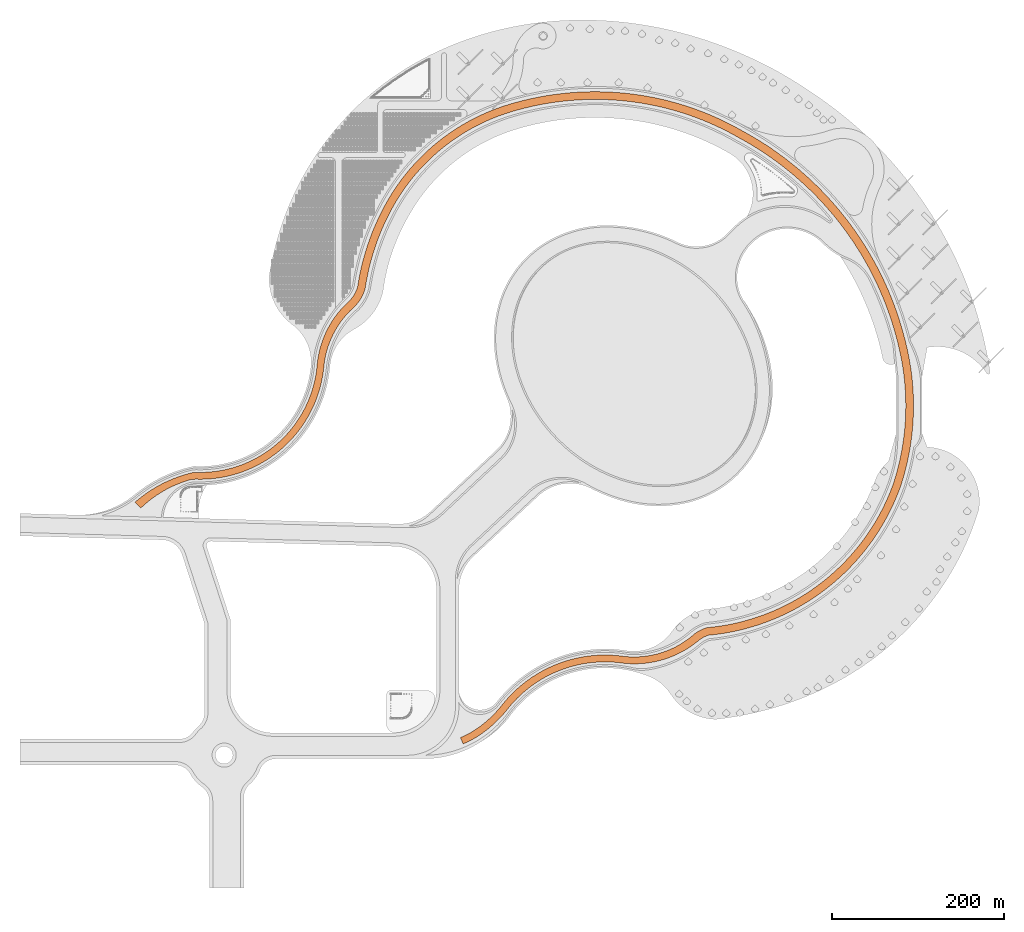
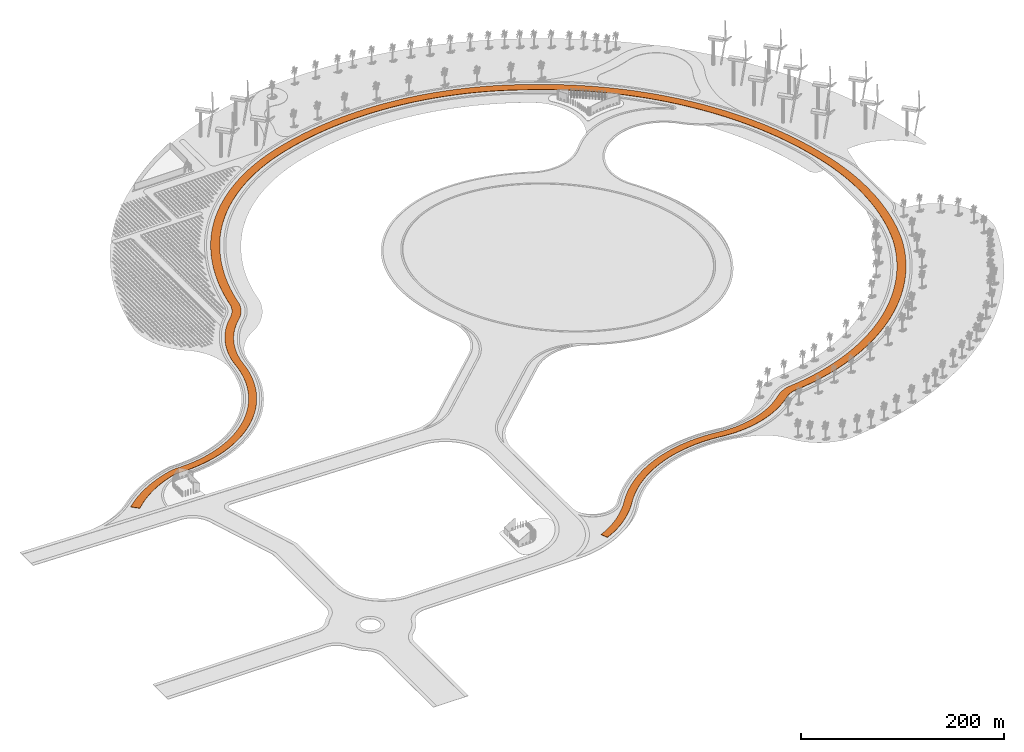
# One storey, part 19 of 39: 1 proxy.
"""IFC2X3 building model written with IfcOpenShell, lengths in millimetres."""

from ifc_helpers import new_model, entity, si_unit, converted_unit, derived_unit, direction, frame, frame_2d, origin, place, context, subcontext, project, spatial, polyline, circle_curve, parameter, trimmed, segment, composite_curve, outline, extrude, source, transform, mapped, material, element, save


model = new_model("IFC2X3")

# Units and contexts
model_context = context("Model", 3, precision=1e-06, world=origin(), true_north=direction((2.0, 6.12303176911189e-17, 1.0)))
context_of_model = context(None, 3, precision=1e-06, world=origin(), true_north=direction((2.0, 6.12303176911189e-17, 1.0)))
body_context = subcontext(model_context, "Body", "Model", "MODEL_VIEW")
ifc_project = project(units=[si_unit("LENGTHUNIT", "METRE", prefix="MILLI"), si_unit("AREAUNIT", "SQUARE_METRE", prefix="MILLI"), si_unit("VOLUMEUNIT", "CUBIC_METRE", prefix="MILLI"), converted_unit("PLANEANGLEUNIT", "DEGREE", entity("IfcRatioMeasure", 0.0174532925199433), si_unit("PLANEANGLEUNIT", "RADIAN"), dimensions=[0, 0, 0, 0, 0, 0, 0]), si_unit("MASSUNIT", "GRAM", prefix="KILO"), si_unit("TIMEUNIT", "SECOND"), si_unit("THERMODYNAMICTEMPERATUREUNIT", "KELVIN"), derived_unit("THERMALTRANSMITTANCEUNIT", [(si_unit("MASSUNIT", "GRAM", prefix="KILO"), 1), (si_unit("THERMODYNAMICTEMPERATUREUNIT", "KELVIN"), -1), (si_unit("TIMEUNIT", "SECOND"), -3)]), derived_unit("VOLUMETRICFLOWRATEUNIT", [(si_unit("LENGTHUNIT", "METRE"), 3), (si_unit("TIMEUNIT", "SECOND"), -1)])], contexts=[model_context, context_of_model])

# Site, building, storey
site_placement = place(None, origin())
site = spatial("IfcSite", under=ifc_project, at=site_placement, CompositionType="ELEMENT")
building_placement = place(site_placement, origin())
building = spatial("IfcBuilding", under=site, at=building_placement, CompositionType="ELEMENT")
storey_placement = place(building_placement, frame((0.0, 0.0, 4000.0)))
storey = spatial("IfcBuildingStorey", under=building, at=storey_placement, Name="Level 2", CompositionType="ELEMENT", Elevation=4000.0)

# Proxy
ifc_material = material(Name="Concrete - Cast In Situ")
shared_shape = source(origin(), body_context, "Body", "SweptSolid", [
    extrude(outline(composite_curve([segment(trimmed(circle_curve(frame_2d((-99945.1977249839, 366080.639228426), x_axis=(0.707106781192124, -0.707106781192124)), 153377.082534401), [parameter(228.571093474193)], [parameter(256.474295548733)], True, "PARAMETER"), True, "CONTINUOUS"), segment(trimmed(circle_curve(frame_2d((-209434.735962853, 299052.911111603), x_axis=(0.707106781192124, -0.707106781192124)), 25000.0), [parameter(256.474295548733)], [parameter(271.53123508796)], True, "PARAMETER"), True, "CONTINUOUS"), segment(trimmed(circle_curve(frame_2d((-320196.14009368, 182207.237871351), x_axis=(0.707106781192124, -0.707106781192124)), 136000.0), [parameter(4.9815972139705)], [parameter(91.5312350879604)], True, "PARAMETER"), False, "CONTINUOUS"), segment(trimmed(circle_curve(frame_2d((-129502.491249376, 22091.8660595066), x_axis=(0.707106781192124, -0.707106781192124)), 113000.0), [parameter(184.98159721397)], [parameter(227.515073999051)], True, "PARAMETER"), True, "CONTINUOUS"), segment(trimmed(circle_curve(frame_2d((-279357.997920674, 15509.5321050072), x_axis=(0.707106781192124, -0.707106781192124)), 37000.0000000003), [parameter(14.0609895870543)], [parameter(47.5150739990519)], True, "PARAMETER"), False, "CONTINUOUS"), segment(trimmed(circle_curve(frame_2d((-18717.8844029428, -172123.696651906), x_axis=(0.707106781192124, -0.707106781192124)), 284300.673568805), [parameter(188.624733618807)], [parameter(209.747234897171)], True, "PARAMETER"), True, "CONTINUOUS"), segment(trimmed(circle_curve(frame_2d((-58446.3403043034, -161290.416559124), x_axis=(0.707106781192124, -0.707106781192124)), 243121.672052558), [parameter(209.747234897171)], [parameter(253.054237224073)], True, "PARAMETER"), True, "CONTINUOUS"), segment(trimmed(circle_curve(frame_2d((31985.5756584906, -113097.052430683), x_axis=(0.707106781192124, -0.707106781192124)), 345593.774454717), [parameter(253.054237224073)], [parameter(279.794088244797)], True, "PARAMETER"), True, "CONTINUOUS"), segment(trimmed(circle_curve(frame_2d((29875.8332063244, -116087.147973775), x_axis=(0.707106781192124, -0.707106781192124)), 341934.309388441), [parameter(279.794088244797)], [parameter(299.846304820939)], True, "PARAMETER"), True, "CONTINUOUS"), segment(trimmed(circle_curve(frame_2d((49718.1370082888, -81249.9484606877), x_axis=(0.707106781192124, -0.707106781192124)), 380879.610665974), [parameter(298.334970728888)], [parameter(348.428671728036)], True, "PARAMETER"), True, "CONTINUOUS"), segment(trimmed(circle_curve(frame_2d((94889.7504614912, -149681.75721206), x_axis=(0.707106781192124, -0.707106781192124)), 298883.347879491), [parameter(348.428671728036)], [parameter(18.1453716192399)], True, "PARAMETER"), True, "CONTINUOUS"), segment(trimmed(circle_curve(frame_2d((124331.369948767, -172413.659831059), x_axis=(0.707106781192124, -0.707106781192124)), 262441.057832065), [parameter(19.6695854405774)], [parameter(84.6646162721357)], True, "PARAMETER"), True, "CONTINUOUS"), segment(trimmed(circle_curve(frame_2d((356781.457737612, 11366.9115315272), x_axis=(0.707106781192124, -0.707106781192124)), 34500.0000000008), [parameter(230.351394862219)], [parameter(253.131051799704)], True, "PARAMETER"), False, "CONTINUOUS"), segment(trimmed(circle_curve(frame_2d((206937.420972124, -2669.27904223895), x_axis=(0.707106781192124, -0.707106781192124)), 116000.0), [parameter(50.3513948622213)], [parameter(97.5305464102445)], True, "PARAMETER"), True, "CONTINUOUS"), segment(trimmed(circle_curve(frame_2d((365123.553823467, 203710.629432621), x_axis=(0.707106781192124, -0.707106781192124)), 144029.842996057), [parameter(218.237592146961)], [parameter(277.530546410243)], True, "PARAMETER"), False, "CONTINUOUS"), segment(trimmed(circle_curve(frame_2d((79097.5402004377, 237626.849552973), x_axis=(0.707106781192124, -0.707106781192124)), 144000.0), [parameter(38.2375921469628)], [parameter(52.8605948468164)], True, "PARAMETER"), True, "CONTINUOUS"), segment(trimmed(circle_curve(frame_2d((105851.499545138, 241320.515667659), x_axis=(0.707106781192124, -0.707106781192124)), 116992.269440313), [parameter(52.8605948468165)], [parameter(67.1797355685542)], True, "PARAMETER"), True, "CONTINUOUS"), segment(polyline([(214186.827971575, 285486.653415155), (206778.794675378, 282466.547012652)]), True, "CONTINUOUS"), segment(trimmed(circle_curve(frame_2d((105851.499545138, 241320.515667659), x_axis=(0.707106781192124, -0.707106781192124)), 108992.269440313), [parameter(52.8605948468161)], [parameter(67.1797355685538)], True, "PARAMETER"), False, "CONTINUOUS"), segment(trimmed(circle_curve(frame_2d((79097.5402004377, 237626.849552973), x_axis=(0.707106781192124, -0.707106781192124)), 136000.0), [parameter(38.2375921469621)], [parameter(52.8605948468159)], True, "PARAMETER"), False, "CONTINUOUS"), segment(trimmed(circle_curve(frame_2d((365123.553823468, 203710.629432621), x_axis=(0.707106781192124, -0.707106781192124)), 152029.842996058), [parameter(218.237592146962)], [parameter(277.523704867413)], True, "PARAMETER"), True, "CONTINUOUS"), segment(trimmed(circle_curve(frame_2d((208738.078234964, -269.573566434556), x_axis=(0.707106781192124, -0.707106781192124)), 105000.0), [parameter(49.4943144119307)], [parameter(97.5237048674133)], True, "PARAMETER"), False, "CONTINUOUS"), segment(trimmed(circle_curve(frame_2d((356781.457737612, 11366.9115315272), x_axis=(0.707106781192124, -0.707106781192124)), 43500.0000000008), [parameter(229.49431441193)], [parameter(254.407331470142)], True, "PARAMETER"), True, "CONTINUOUS"), segment(trimmed(circle_curve(frame_2d((124331.369948767, -172413.659831059), x_axis=(0.707106781192124, -0.707106781192124)), 253441.057832065), [parameter(19.6334845168712)], [parameter(84.8563227883896)], True, "PARAMETER"), False, "CONTINUOUS"), segment(trimmed(circle_curve(frame_2d((94857.5052380553, -149632.907972516), x_axis=(0.707106781192124, -0.707106781192124)), 289941.879944536), [parameter(348.428671728063)], [parameter(18.0607855307022)], True, "PARAMETER"), False, "CONTINUOUS"), segment(trimmed(circle_curve(frame_2d((49706.6823718326, -81232.5954942777), x_axis=(0.707106781192124, -0.707106781192124)), 371900.40331226), [parameter(298.276527929819)], [parameter(348.428671728063)], True, "PARAMETER"), False, "CONTINUOUS"), segment(trimmed(circle_curve(frame_2d((29875.8332063244, -116087.147973775), x_axis=(0.707106781192124, -0.707106781192124)), 332934.309388441), [parameter(279.794088244796)], [parameter(299.819118006767)], True, "PARAMETER"), False, "CONTINUOUS"), segment(trimmed(circle_curve(frame_2d((31985.5756584906, -113097.052430683), x_axis=(0.707106781192124, -0.707106781192124)), 336593.774454717), [parameter(253.054237224072)], [parameter(279.794088244796)], True, "PARAMETER"), False, "CONTINUOUS"), segment(trimmed(circle_curve(frame_2d((-58446.3403043034, -161290.416559124), x_axis=(0.707106781192124, -0.707106781192124)), 234121.672052558), [parameter(209.74723489717)], [parameter(253.054237224072)], True, "PARAMETER"), False, "CONTINUOUS"), segment(trimmed(circle_curve(frame_2d((-18717.8844029428, -172123.696651906), x_axis=(0.707106781192124, -0.707106781192124)), 275300.673568805), [parameter(188.541363891003)], [parameter(209.74723489717)], True, "PARAMETER"), False, "CONTINUOUS"), segment(trimmed(circle_curve(frame_2d((-279357.997920674, 15509.5321050072), x_axis=(0.707106781192124, -0.707106781192124)), 46000.0000000003), [parameter(13.4956324090255)], [parameter(47.782478863977)], True, "PARAMETER"), True, "CONTINUOUS"), segment(trimmed(circle_curve(frame_2d((-127537.201516744, 22888.2704305328), x_axis=(0.707106781192124, -0.707106781192124)), 106000.0), [parameter(185.411013406251)], [parameter(227.782478863975)], True, "PARAMETER"), False, "CONTINUOUS"), segment(trimmed(circle_curve(frame_2d((-320196.140093679, 182207.237871351), x_axis=(0.707106781192124, -0.707106781192124)), 144000.0), [parameter(5.41101340625254)], [parameter(91.4342230240254)], True, "PARAMETER"), True, "CONTINUOUS"), segment(trimmed(circle_curve(frame_2d((-196831.690423129, 311907.710335727), x_axis=(0.707106781192124, -0.707106781192124)), 35000.0), [parameter(252.73848772807)], [parameter(271.434223024023)], True, "PARAMETER"), False, "CONTINUOUS"), segment(trimmed(circle_curve(frame_2d((-107030.781633774, 359131.218454057), x_axis=(0.707106781192124, -0.707106781192124)), 136460.647240179), [parameter(226.093398884286)], [parameter(252.738487728071)], True, "PARAMETER"), False, "CONTINUOUS"), segment(polyline([(-243466.581743559, 356527.241954255), (-253024.464927588, 356527.241954255)]), True, "CONTINUOUS")], self_intersect=False)), frame((40672.8917737796, 308631.218412363, 4400.0), z_axis=(0.0, 0.0, -1.0), x_axis=(0.707106781186546, -0.707106781186549, 0.0)), (0.0, 0.0, -1.0), 400.0),
])
proxy_placement = place(storey_placement, frame((0.0, 0.0, -4000.0)))
element("IfcBuildingElementProxy", 1, at=proxy_placement, inside=storey, material=ifc_material, Name="Track:Track", ObjectType="Track", CompositionType="ELEMENT", context=body_context, shape_type="MappedRepresentation", body=[
    mapped(shared_shape, transform((0.0, 0.0, 0.0), scale=1.0)),
])

save(model, "model.ifc")
